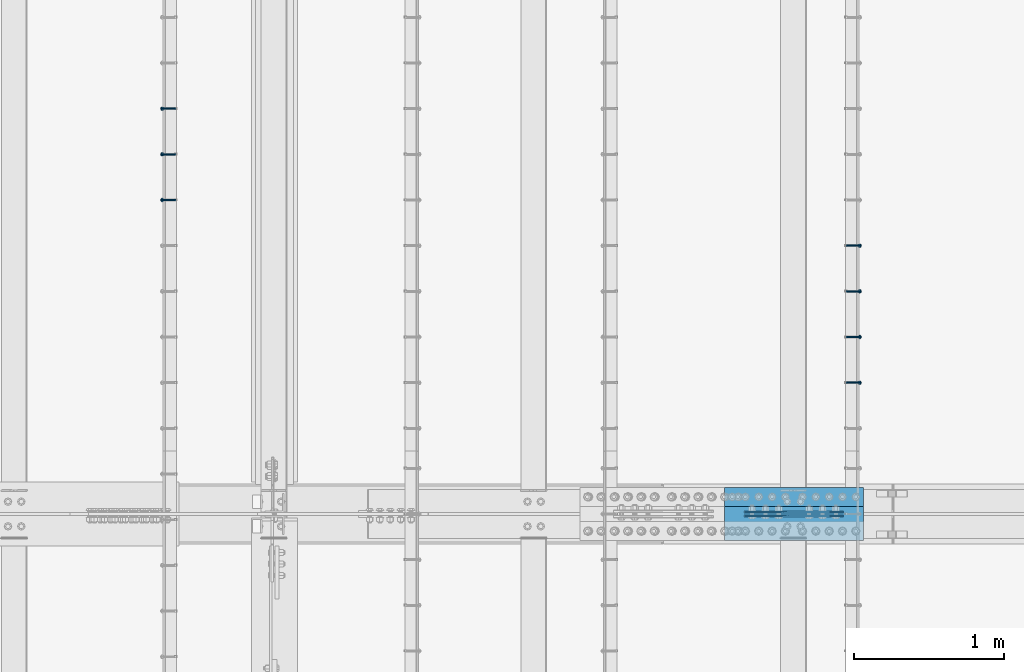
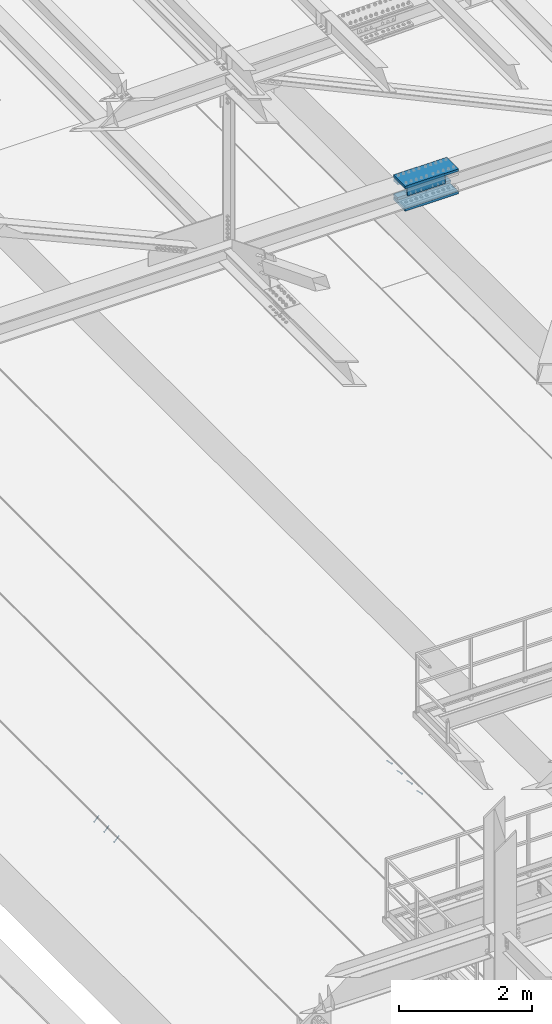
# One storey, part 2233 of 3843: 7 members, 6 beams, 3 elements without a shape of their own.
"""IFC2X3 building model written with IfcOpenShell, lengths in millimetres."""

from ifc_helpers import new_model, si_unit, frame, origin_with_axes, place, context, subcontext, project, spatial, faceted_brep, material, type_object, element, aggregate, save


model = new_model("IFC2X3")

# Units and contexts
model_context = context("Model", 3, precision=1e-05, world=origin_with_axes())
body_context = subcontext(model_context, "Body", "Model", "MODEL_VIEW")
ifc_project = project(units=[si_unit("LENGTHUNIT", "METRE", prefix="MILLI"), si_unit("AREAUNIT", "SQUARE_METRE"), si_unit("VOLUMEUNIT", "CUBIC_METRE"), si_unit("MASSUNIT", "GRAM", prefix="KILO"), si_unit("TIMEUNIT", "SECOND"), si_unit("PLANEANGLEUNIT", "RADIAN"), si_unit("SOLIDANGLEUNIT", "STERADIAN"), si_unit("THERMODYNAMICTEMPERATUREUNIT", "DEGREE_CELSIUS"), si_unit("LUMINOUSINTENSITYUNIT", "LUMEN")], contexts=[model_context])

# Site, building, storey
site_placement = place(None, origin_with_axes())
site = spatial("IfcSite", under=ifc_project, at=site_placement, CompositionType="ELEMENT")
building_placement = place(site_placement, origin_with_axes())
building = spatial("IfcBuilding", under=site, at=building_placement, Name="Undefined", CompositionType="ELEMENT")
storey_placement = place(building_placement, origin_with_axes())
storey = spatial("IfcBuildingStorey", under=building, at=storey_placement, Name="Undefined", CompositionType="ELEMENT", Elevation=0.0)

# Assembly, members
assembly_1_placement = place(storey_placement, origin_with_axes())
assembly_1 = element("IfcElementAssembly", 1, at=assembly_1_placement, inside=storey, Name="EMBED_ANGLE", AssemblyPlace="NOTDEFINED", PredefinedType="RIGID_FRAME")
ifc_material_1 = material(Name="STEEL/A108")
member_type = type_object("IfcMemberType", PredefinedType="NOTDEFINED")
member_1_placement = place(assembly_1_placement, frame((52815.2360419921, 34721.7996154785, 30446.6625), z_axis=(0.0, 1.0, 0.0), x_axis=(0.707106781186548, 0.0, -0.707106781186548)))
member_1 = element("IfcMember", 2, at=member_1_placement, type_object=member_type, material=ifc_material_1, Name="HEADED STUD ANCHOR", context=body_context, shape_type="Brep", body=[
    faceted_brep([(7.27595761418343e-12, -3.18000006675175, 5.5), (0.0, -5.49999999998363, 3.1800000667572), (118.110000000976, -5.49999999999091, 3.1800000667572), (118.110000000983, -3.18000006675175, 5.5), (0.0, -6.3499999046162, 0.0), (118.110000000968, -6.34999990461256, 0.0), (0.0, -5.49999999998363, -3.1800000667572), (118.110000000976, -5.49999999999091, -3.1800000667572), (7.27595761418343e-12, -3.18000006675175, -5.5), (118.110000000983, -3.18000006675175, -5.5), (7.27595761418343e-12, -1.81898940354586e-12, -6.34999990463257), (118.110000000968, -1.81898940354586e-12, -6.34999990463257), (0.0, 3.18000006675175, -5.5), (118.110000000968, 3.18000006674811, -5.5), (7.27595761418343e-12, 5.49999999998363, -3.1800000667572), (118.110000000983, 5.49999999998363, -3.1800000667572), (7.27595761418343e-12, 6.3499999046162, 0.0), (118.110000000976, 6.34999990461256, 0.0), (7.27595761418343e-12, 5.49999999998363, 3.1800000667572), (118.110000000983, 5.49999999998363, 3.1800000667572), (0.0, 3.18000006675175, 5.5), (118.110000000968, 3.18000006674811, 5.5), (7.27595761418343e-12, -1.81898940354586e-12, 6.34999990463257), (118.110000000968, -1.81898940354586e-12, 6.34999990463257), (120.650000000991, -10.9899997710909, 6.34999990463257), (120.650000000998, -6.34000015257152, 10.9899997711182), (120.650000000991, -12.6999998092379, 0.0), (120.650000000991, -10.9899997710909, -6.34999990463257), (120.650000000998, -6.34000015257152, -10.9899997711182), (120.650000000991, -1.81898940354586e-12, -12.6899995803833), (120.650000000991, 6.34000015257152, -10.9899997711182), (120.650000000998, 10.9899997710909, -6.34999990463257), (120.650000000991, 12.6999998092342, 0.0), (120.650000000998, 10.9899997710909, 6.34999990463257), (120.650000000991, 6.34000015257152, 10.9899997711182), (120.650000000991, -1.81898940354586e-12, 12.6899995803833), (127.000000001048, -10.9899997710945, 6.34999990463257), (127.000000001048, -6.34000015257152, 10.9899997711182), (127.000000001048, -12.6999998092342, 0.0), (127.000000001048, -10.9899997710945, -6.34999990463257), (127.000000001048, -6.34000015257152, -10.9899997711182), (127.000000001048, 1.81898940354586e-12, -12.6899995803833), (127.000000001048, 6.34000015256788, -10.9899997711182), (127.000000001048, 10.9899997710909, -6.34999990463257), (127.000000001048, 12.6999998092379, 0.0), (127.000000001048, 10.9899997710909, 6.34999990463257), (127.000000001048, 6.34000015256788, 10.9899997711182), (127.000000001048, 1.81898940354586e-12, 12.6899995803833)], [[[0, 1, 2, 3]], [[1, 4, 5, 2]], [[4, 6, 7, 5]], [[6, 8, 9, 7]], [[8, 10, 11, 9]], [[10, 12, 13, 11]], [[12, 14, 15, 13]], [[14, 16, 17, 15]], [[16, 18, 19, 17]], [[18, 20, 21, 19]], [[20, 22, 23, 21]], [[22, 0, 3, 23]], [[22, 20, 18, 16, 14, 12, 10, 8, 6, 4, 1, 0]], [[3, 2, 24, 25]], [[2, 5, 26, 24]], [[5, 7, 27, 26]], [[7, 9, 28, 27]], [[9, 11, 29, 28]], [[11, 13, 30, 29]], [[13, 15, 31, 30]], [[15, 17, 32, 31]], [[17, 19, 33, 32]], [[19, 21, 34, 33]], [[21, 23, 35, 34]], [[23, 3, 25, 35]], [[25, 24, 36, 37]], [[24, 26, 38, 36]], [[26, 27, 39, 38]], [[27, 28, 40, 39]], [[28, 29, 41, 40]], [[29, 30, 42, 41]], [[30, 31, 43, 42]], [[31, 32, 44, 43]], [[32, 33, 45, 44]], [[33, 34, 46, 45]], [[34, 35, 47, 46]], [[35, 25, 37, 47]], [[38, 39, 40, 41, 42, 43, 44, 45, 46, 47, 37, 36]]]),
])
member_2_placement = place(assembly_1_placement, frame((52815.2360419921, 35026.5996154785, 30446.6625), z_axis=(0.0, 1.0, 0.0), x_axis=(0.707106781186548, 0.0, -0.707106781186548)))
member_2 = element("IfcMember", 3, at=member_2_placement, type_object=member_type, material=ifc_material_1, Name="HEADED STUD ANCHOR", context=body_context, shape_type="Brep", body=[
    faceted_brep([(7.27595761418343e-12, -3.18000006675175, 5.5), (0.0, -5.49999999998363, 3.1800000667572), (118.110000000976, -5.49999999999091, 3.1800000667572), (118.110000000983, -3.18000006675175, 5.5), (0.0, -6.3499999046162, 0.0), (118.110000000968, -6.34999990461256, 0.0), (0.0, -5.49999999998363, -3.1800000667572), (118.110000000976, -5.49999999999091, -3.1800000667572), (7.27595761418343e-12, -3.18000006675175, -5.5), (118.110000000983, -3.18000006675175, -5.5), (7.27595761418343e-12, -1.81898940354586e-12, -6.34999990463257), (118.110000000968, -1.81898940354586e-12, -6.34999990463257), (0.0, 3.18000006675175, -5.5), (118.110000000968, 3.18000006674811, -5.5), (7.27595761418343e-12, 5.49999999998363, -3.1800000667572), (118.110000000983, 5.49999999998363, -3.1800000667572), (7.27595761418343e-12, 6.3499999046162, 0.0), (118.110000000976, 6.34999990461256, 0.0), (7.27595761418343e-12, 5.49999999998363, 3.1800000667572), (118.110000000983, 5.49999999998363, 3.1800000667572), (0.0, 3.18000006675175, 5.5), (118.110000000968, 3.18000006674811, 5.5), (7.27595761418343e-12, -1.81898940354586e-12, 6.34999990463257), (118.110000000968, -1.81898940354586e-12, 6.34999990463257), (120.650000000991, -10.9899997710909, 6.34999990463257), (120.650000000998, -6.34000015257152, 10.9899997711182), (120.650000000991, -12.6999998092379, 0.0), (120.650000000991, -10.9899997710909, -6.34999990463257), (120.650000000998, -6.34000015257152, -10.9899997711182), (120.650000000991, -1.81898940354586e-12, -12.6899995803833), (120.650000000991, 6.34000015257152, -10.9899997711182), (120.650000000998, 10.9899997710909, -6.34999990463257), (120.650000000991, 12.6999998092342, 0.0), (120.650000000998, 10.9899997710909, 6.34999990463257), (120.650000000991, 6.34000015257152, 10.9899997711182), (120.650000000991, -1.81898940354586e-12, 12.6899995803833), (127.000000001048, -10.9899997710945, 6.34999990463257), (127.000000001048, -6.34000015257152, 10.9899997711182), (127.000000001048, -12.6999998092342, 0.0), (127.000000001048, -10.9899997710945, -6.34999990463257), (127.000000001048, -6.34000015257152, -10.9899997711182), (127.000000001048, 1.81898940354586e-12, -12.6899995803833), (127.000000001048, 6.34000015256788, -10.9899997711182), (127.000000001048, 10.9899997710909, -6.34999990463257), (127.000000001048, 12.6999998092379, 0.0), (127.000000001048, 10.9899997710909, 6.34999990463257), (127.000000001048, 6.34000015256788, 10.9899997711182), (127.000000001048, 1.81898940354586e-12, 12.6899995803833)], [[[0, 1, 2, 3]], [[1, 4, 5, 2]], [[4, 6, 7, 5]], [[6, 8, 9, 7]], [[8, 10, 11, 9]], [[10, 12, 13, 11]], [[12, 14, 15, 13]], [[14, 16, 17, 15]], [[16, 18, 19, 17]], [[18, 20, 21, 19]], [[20, 22, 23, 21]], [[22, 0, 3, 23]], [[22, 20, 18, 16, 14, 12, 10, 8, 6, 4, 1, 0]], [[3, 2, 24, 25]], [[2, 5, 26, 24]], [[5, 7, 27, 26]], [[7, 9, 28, 27]], [[9, 11, 29, 28]], [[11, 13, 30, 29]], [[13, 15, 31, 30]], [[15, 17, 32, 31]], [[17, 19, 33, 32]], [[19, 21, 34, 33]], [[21, 23, 35, 34]], [[23, 3, 25, 35]], [[25, 24, 36, 37]], [[24, 26, 38, 36]], [[26, 27, 39, 38]], [[27, 28, 40, 39]], [[28, 29, 41, 40]], [[29, 30, 42, 41]], [[30, 31, 43, 42]], [[31, 32, 44, 43]], [[32, 33, 45, 44]], [[33, 34, 46, 45]], [[34, 35, 47, 46]], [[35, 25, 37, 47]], [[38, 39, 40, 41, 42, 43, 44, 45, 46, 47, 37, 36]]]),
])
member_3_placement = place(assembly_1_placement, frame((52815.2360419921, 35331.3996154785, 30446.6625), z_axis=(0.0, 1.0, 0.0), x_axis=(0.707106781186548, 0.0, -0.707106781186548)))
member_3 = element("IfcMember", 4, at=member_3_placement, type_object=member_type, material=ifc_material_1, Name="HEADED STUD ANCHOR", context=body_context, shape_type="Brep", body=[
    faceted_brep([(7.27595761418343e-12, -3.18000006675175, 5.5), (0.0, -5.49999999998363, 3.1800000667572), (118.110000000976, -5.49999999999091, 3.1800000667572), (118.110000000983, -3.18000006675175, 5.5), (0.0, -6.3499999046162, 0.0), (118.110000000968, -6.34999990461256, 0.0), (0.0, -5.49999999998363, -3.1800000667572), (118.110000000976, -5.49999999999091, -3.1800000667572), (7.27595761418343e-12, -3.18000006675175, -5.5), (118.110000000983, -3.18000006675175, -5.5), (7.27595761418343e-12, -1.81898940354586e-12, -6.34999990463257), (118.110000000968, -1.81898940354586e-12, -6.34999990463257), (0.0, 3.18000006675175, -5.5), (118.110000000968, 3.18000006674811, -5.5), (7.27595761418343e-12, 5.49999999998363, -3.1800000667572), (118.110000000983, 5.49999999998363, -3.1800000667572), (7.27595761418343e-12, 6.3499999046162, 0.0), (118.110000000976, 6.34999990461256, 0.0), (7.27595761418343e-12, 5.49999999998363, 3.1800000667572), (118.110000000983, 5.49999999998363, 3.1800000667572), (0.0, 3.18000006675175, 5.5), (118.110000000968, 3.18000006674811, 5.5), (7.27595761418343e-12, -1.81898940354586e-12, 6.34999990463257), (118.110000000968, -1.81898940354586e-12, 6.34999990463257), (120.650000000991, -10.9899997710909, 6.34999990463257), (120.650000000998, -6.34000015257152, 10.9899997711182), (120.650000000991, -12.6999998092379, 0.0), (120.650000000991, -10.9899997710909, -6.34999990463257), (120.650000000998, -6.34000015257152, -10.9899997711182), (120.650000000991, -1.81898940354586e-12, -12.6899995803833), (120.650000000991, 6.34000015257152, -10.9899997711182), (120.650000000998, 10.9899997710909, -6.34999990463257), (120.650000000991, 12.6999998092342, 0.0), (120.650000000998, 10.9899997710909, 6.34999990463257), (120.650000000991, 6.34000015257152, 10.9899997711182), (120.650000000991, -1.81898940354586e-12, 12.6899995803833), (127.000000001048, -10.9899997710945, 6.34999990463257), (127.000000001048, -6.34000015257152, 10.9899997711182), (127.000000001048, -12.6999998092342, 0.0), (127.000000001048, -10.9899997710945, -6.34999990463257), (127.000000001048, -6.34000015257152, -10.9899997711182), (127.000000001048, 1.81898940354586e-12, -12.6899995803833), (127.000000001048, 6.34000015256788, -10.9899997711182), (127.000000001048, 10.9899997710909, -6.34999990463257), (127.000000001048, 12.6999998092379, 0.0), (127.000000001048, 10.9899997710909, 6.34999990463257), (127.000000001048, 6.34000015256788, 10.9899997711182), (127.000000001048, 1.81898940354586e-12, 12.6899995803833)], [[[0, 1, 2, 3]], [[1, 4, 5, 2]], [[4, 6, 7, 5]], [[6, 8, 9, 7]], [[8, 10, 11, 9]], [[10, 12, 13, 11]], [[12, 14, 15, 13]], [[14, 16, 17, 15]], [[16, 18, 19, 17]], [[18, 20, 21, 19]], [[20, 22, 23, 21]], [[22, 0, 3, 23]], [[22, 20, 18, 16, 14, 12, 10, 8, 6, 4, 1, 0]], [[3, 2, 24, 25]], [[2, 5, 26, 24]], [[5, 7, 27, 26]], [[7, 9, 28, 27]], [[9, 11, 29, 28]], [[11, 13, 30, 29]], [[13, 15, 31, 30]], [[15, 17, 32, 31]], [[17, 19, 33, 32]], [[19, 21, 34, 33]], [[21, 23, 35, 34]], [[23, 3, 25, 35]], [[25, 24, 36, 37]], [[24, 26, 38, 36]], [[26, 27, 39, 38]], [[27, 28, 40, 39]], [[28, 29, 41, 40]], [[29, 30, 42, 41]], [[30, 31, 43, 42]], [[31, 32, 44, 43]], [[32, 33, 45, 44]], [[33, 34, 46, 45]], [[34, 35, 47, 46]], [[35, 25, 37, 47]], [[38, 39, 40, 41, 42, 43, 44, 45, 46, 47, 37, 36]]]),
])
member_4_placement = place(assembly_1_placement, frame((52815.2360419921, 35636.1996154785, 30446.6625), z_axis=(0.0, 1.0, 0.0), x_axis=(0.707106781186548, 0.0, -0.707106781186548)))
member_4 = element("IfcMember", 5, at=member_4_placement, type_object=member_type, material=ifc_material_1, Name="HEADED STUD ANCHOR", context=body_context, shape_type="Brep", body=[
    faceted_brep([(7.27595761418343e-12, -3.18000006675175, 5.5), (0.0, -5.49999999998363, 3.1800000667572), (118.110000000976, -5.49999999999091, 3.1800000667572), (118.110000000983, -3.18000006675175, 5.5), (0.0, -6.3499999046162, 0.0), (118.110000000968, -6.34999990461256, 0.0), (0.0, -5.49999999998363, -3.1800000667572), (118.110000000976, -5.49999999999091, -3.1800000667572), (7.27595761418343e-12, -3.18000006675175, -5.5), (118.110000000983, -3.18000006675175, -5.5), (7.27595761418343e-12, -1.81898940354586e-12, -6.34999990463257), (118.110000000968, -1.81898940354586e-12, -6.34999990463257), (0.0, 3.18000006675175, -5.5), (118.110000000968, 3.18000006674811, -5.5), (7.27595761418343e-12, 5.49999999998363, -3.1800000667572), (118.110000000983, 5.49999999998363, -3.1800000667572), (7.27595761418343e-12, 6.3499999046162, 0.0), (118.110000000976, 6.34999990461256, 0.0), (7.27595761418343e-12, 5.49999999998363, 3.1800000667572), (118.110000000983, 5.49999999998363, 3.1800000667572), (0.0, 3.18000006675175, 5.5), (118.110000000968, 3.18000006674811, 5.5), (7.27595761418343e-12, -1.81898940354586e-12, 6.34999990463257), (118.110000000968, -1.81898940354586e-12, 6.34999990463257), (120.650000000991, -10.9899997710909, 6.34999990463257), (120.650000000998, -6.34000015257152, 10.9899997711182), (120.650000000991, -12.6999998092379, 0.0), (120.650000000991, -10.9899997710909, -6.34999990463257), (120.650000000998, -6.34000015257152, -10.9899997711182), (120.650000000991, -1.81898940354586e-12, -12.6899995803833), (120.650000000991, 6.34000015257152, -10.9899997711182), (120.650000000998, 10.9899997710909, -6.34999990463257), (120.650000000991, 12.6999998092342, 0.0), (120.650000000998, 10.9899997710909, 6.34999990463257), (120.650000000991, 6.34000015257152, 10.9899997711182), (120.650000000991, -1.81898940354586e-12, 12.6899995803833), (127.000000001048, -10.9899997710945, 6.34999990463257), (127.000000001048, -6.34000015257152, 10.9899997711182), (127.000000001048, -12.6999998092342, 0.0), (127.000000001048, -10.9899997710945, -6.34999990463257), (127.000000001048, -6.34000015257152, -10.9899997711182), (127.000000001048, 1.81898940354586e-12, -12.6899995803833), (127.000000001048, 6.34000015256788, -10.9899997711182), (127.000000001048, 10.9899997710909, -6.34999990463257), (127.000000001048, 12.6999998092379, 0.0), (127.000000001048, 10.9899997710909, 6.34999990463257), (127.000000001048, 6.34000015256788, 10.9899997711182), (127.000000001048, 1.81898940354586e-12, 12.6899995803833)], [[[0, 1, 2, 3]], [[1, 4, 5, 2]], [[4, 6, 7, 5]], [[6, 8, 9, 7]], [[8, 10, 11, 9]], [[10, 12, 13, 11]], [[12, 14, 15, 13]], [[14, 16, 17, 15]], [[16, 18, 19, 17]], [[18, 20, 21, 19]], [[20, 22, 23, 21]], [[22, 0, 3, 23]], [[22, 20, 18, 16, 14, 12, 10, 8, 6, 4, 1, 0]], [[3, 2, 24, 25]], [[2, 5, 26, 24]], [[5, 7, 27, 26]], [[7, 9, 28, 27]], [[9, 11, 29, 28]], [[11, 13, 30, 29]], [[13, 15, 31, 30]], [[15, 17, 32, 31]], [[17, 19, 33, 32]], [[19, 21, 34, 33]], [[21, 23, 35, 34]], [[23, 3, 25, 35]], [[25, 24, 36, 37]], [[24, 26, 38, 36]], [[26, 27, 39, 38]], [[27, 28, 40, 39]], [[28, 29, 41, 40]], [[29, 30, 42, 41]], [[30, 31, 43, 42]], [[31, 32, 44, 43]], [[32, 33, 45, 44]], [[33, 34, 46, 45]], [[34, 35, 47, 46]], [[35, 25, 37, 47]], [[38, 39, 40, 41, 42, 43, 44, 45, 46, 47, 37, 36]]]),
])
aggregate(assembly_1, [member_1, member_2, member_3, member_4])

assembly_2_placement = place(storey_placement, origin_with_axes())
assembly_2 = element("IfcElementAssembly", 6, at=assembly_2_placement, inside=storey, Name="EMBED_ANGLE", AssemblyPlace="NOTDEFINED", PredefinedType="RIGID_FRAME")
member_5_placement = place(assembly_2_placement, frame((48335.3741210938, 35941.0003845215, 30446.6625), z_axis=(0.0, -1.0, 0.0), x_axis=(-0.707106781186548, 0.0, -0.707106781186548)))
member_5 = element("IfcMember", 7, at=member_5_placement, type_object=member_type, material=ifc_material_1, Name="HEADED STUD ANCHOR", context=body_context, shape_type="Brep", body=[
    faceted_brep([(7.27595761418343e-12, -3.18000006675175, 5.5), (0.0, -5.49999999998363, 3.1800000667572), (118.110000000976, -5.49999999999091, 3.1800000667572), (118.110000000983, -3.18000006675175, 5.5), (0.0, -6.3499999046162, 0.0), (118.110000000968, -6.34999990461256, 0.0), (0.0, -5.49999999998363, -3.1800000667572), (118.110000000976, -5.49999999999091, -3.1800000667572), (7.27595761418343e-12, -3.18000006675175, -5.5), (118.110000000983, -3.18000006675175, -5.5), (7.27595761418343e-12, -1.81898940354586e-12, -6.34999990463257), (118.110000000968, -1.81898940354586e-12, -6.34999990463257), (0.0, 3.18000006675175, -5.5), (118.110000000968, 3.18000006674811, -5.5), (7.27595761418343e-12, 5.49999999998363, -3.1800000667572), (118.110000000983, 5.49999999998363, -3.1800000667572), (7.27595761418343e-12, 6.3499999046162, 0.0), (118.110000000976, 6.34999990461256, 0.0), (7.27595761418343e-12, 5.49999999998363, 3.1800000667572), (118.110000000983, 5.49999999998363, 3.1800000667572), (0.0, 3.18000006675175, 5.5), (118.110000000968, 3.18000006674811, 5.5), (7.27595761418343e-12, -1.81898940354586e-12, 6.34999990463257), (118.110000000968, -1.81898940354586e-12, 6.34999990463257), (120.650000000991, -10.9899997710909, 6.34999990463257), (120.650000000998, -6.34000015257152, 10.9899997711182), (120.650000000991, -12.6999998092379, 0.0), (120.650000000991, -10.9899997710909, -6.34999990463257), (120.650000000998, -6.34000015257152, -10.9899997711182), (120.650000000991, -1.81898940354586e-12, -12.6899995803833), (120.650000000991, 6.34000015257152, -10.9899997711182), (120.650000000998, 10.9899997710909, -6.34999990463257), (120.650000000991, 12.6999998092342, 0.0), (120.650000000998, 10.9899997710909, 6.34999990463257), (120.650000000991, 6.34000015257152, 10.9899997711182), (120.650000000991, -1.81898940354586e-12, 12.6899995803833), (127.000000001048, -10.9899997710945, 6.34999990463257), (127.000000001048, -6.34000015257152, 10.9899997711182), (127.000000001048, -12.6999998092342, 0.0), (127.000000001048, -10.9899997710945, -6.34999990463257), (127.000000001048, -6.34000015257152, -10.9899997711182), (127.000000001048, 1.81898940354586e-12, -12.6899995803833), (127.000000001048, 6.34000015256788, -10.9899997711182), (127.000000001048, 10.9899997710909, -6.34999990463257), (127.000000001048, 12.6999998092379, 0.0), (127.000000001048, 10.9899997710909, 6.34999990463257), (127.000000001048, 6.34000015256788, 10.9899997711182), (127.000000001048, 1.81898940354586e-12, 12.6899995803833)], [[[0, 1, 2, 3]], [[1, 4, 5, 2]], [[4, 6, 7, 5]], [[6, 8, 9, 7]], [[8, 10, 11, 9]], [[10, 12, 13, 11]], [[12, 14, 15, 13]], [[14, 16, 17, 15]], [[16, 18, 19, 17]], [[18, 20, 21, 19]], [[20, 22, 23, 21]], [[22, 0, 3, 23]], [[22, 20, 18, 16, 14, 12, 10, 8, 6, 4, 1, 0]], [[3, 2, 24, 25]], [[2, 5, 26, 24]], [[5, 7, 27, 26]], [[7, 9, 28, 27]], [[9, 11, 29, 28]], [[11, 13, 30, 29]], [[13, 15, 31, 30]], [[15, 17, 32, 31]], [[17, 19, 33, 32]], [[19, 21, 34, 33]], [[21, 23, 35, 34]], [[23, 3, 25, 35]], [[25, 24, 36, 37]], [[24, 26, 38, 36]], [[26, 27, 39, 38]], [[27, 28, 40, 39]], [[28, 29, 41, 40]], [[29, 30, 42, 41]], [[30, 31, 43, 42]], [[31, 32, 44, 43]], [[32, 33, 45, 44]], [[33, 34, 46, 45]], [[34, 35, 47, 46]], [[35, 25, 37, 47]], [[38, 39, 40, 41, 42, 43, 44, 45, 46, 47, 37, 36]]]),
])
member_6_placement = place(assembly_2_placement, frame((48335.3741210938, 36245.8003845215, 30446.6625), z_axis=(0.0, -1.0, 0.0), x_axis=(-0.707106781186548, 0.0, -0.707106781186548)))
member_6 = element("IfcMember", 8, at=member_6_placement, type_object=member_type, material=ifc_material_1, Name="HEADED STUD ANCHOR", context=body_context, shape_type="Brep", body=[
    faceted_brep([(7.27595761418343e-12, -3.18000006675175, 5.5), (0.0, -5.49999999998363, 3.1800000667572), (118.110000000976, -5.49999999999091, 3.1800000667572), (118.110000000983, -3.18000006675175, 5.5), (0.0, -6.3499999046162, 0.0), (118.110000000968, -6.34999990461256, 0.0), (0.0, -5.49999999998363, -3.1800000667572), (118.110000000976, -5.49999999999091, -3.1800000667572), (7.27595761418343e-12, -3.18000006675175, -5.5), (118.110000000983, -3.18000006675175, -5.5), (7.27595761418343e-12, -1.81898940354586e-12, -6.34999990463257), (118.110000000968, -1.81898940354586e-12, -6.34999990463257), (0.0, 3.18000006675175, -5.5), (118.110000000968, 3.18000006674811, -5.5), (7.27595761418343e-12, 5.49999999998363, -3.1800000667572), (118.110000000983, 5.49999999998363, -3.1800000667572), (7.27595761418343e-12, 6.3499999046162, 0.0), (118.110000000976, 6.34999990461256, 0.0), (7.27595761418343e-12, 5.49999999998363, 3.1800000667572), (118.110000000983, 5.49999999998363, 3.1800000667572), (0.0, 3.18000006675175, 5.5), (118.110000000968, 3.18000006674811, 5.5), (7.27595761418343e-12, -1.81898940354586e-12, 6.34999990463257), (118.110000000968, -1.81898940354586e-12, 6.34999990463257), (120.650000000991, -10.9899997710909, 6.34999990463257), (120.650000000998, -6.34000015257152, 10.9899997711182), (120.650000000991, -12.6999998092379, 0.0), (120.650000000991, -10.9899997710909, -6.34999990463257), (120.650000000998, -6.34000015257152, -10.9899997711182), (120.650000000991, -1.81898940354586e-12, -12.6899995803833), (120.650000000991, 6.34000015257152, -10.9899997711182), (120.650000000998, 10.9899997710909, -6.34999990463257), (120.650000000991, 12.6999998092342, 0.0), (120.650000000998, 10.9899997710909, 6.34999990463257), (120.650000000991, 6.34000015257152, 10.9899997711182), (120.650000000991, -1.81898940354586e-12, 12.6899995803833), (127.000000001048, -10.9899997710945, 6.34999990463257), (127.000000001048, -6.34000015257152, 10.9899997711182), (127.000000001048, -12.6999998092342, 0.0), (127.000000001048, -10.9899997710945, -6.34999990463257), (127.000000001048, -6.34000015257152, -10.9899997711182), (127.000000001048, 1.81898940354586e-12, -12.6899995803833), (127.000000001048, 6.34000015256788, -10.9899997711182), (127.000000001048, 10.9899997710909, -6.34999990463257), (127.000000001048, 12.6999998092379, 0.0), (127.000000001048, 10.9899997710909, 6.34999990463257), (127.000000001048, 6.34000015256788, 10.9899997711182), (127.000000001048, 1.81898940354586e-12, 12.6899995803833)], [[[0, 1, 2, 3]], [[1, 4, 5, 2]], [[4, 6, 7, 5]], [[6, 8, 9, 7]], [[8, 10, 11, 9]], [[10, 12, 13, 11]], [[12, 14, 15, 13]], [[14, 16, 17, 15]], [[16, 18, 19, 17]], [[18, 20, 21, 19]], [[20, 22, 23, 21]], [[22, 0, 3, 23]], [[22, 20, 18, 16, 14, 12, 10, 8, 6, 4, 1, 0]], [[3, 2, 24, 25]], [[2, 5, 26, 24]], [[5, 7, 27, 26]], [[7, 9, 28, 27]], [[9, 11, 29, 28]], [[11, 13, 30, 29]], [[13, 15, 31, 30]], [[15, 17, 32, 31]], [[17, 19, 33, 32]], [[19, 21, 34, 33]], [[21, 23, 35, 34]], [[23, 3, 25, 35]], [[25, 24, 36, 37]], [[24, 26, 38, 36]], [[26, 27, 39, 38]], [[27, 28, 40, 39]], [[28, 29, 41, 40]], [[29, 30, 42, 41]], [[30, 31, 43, 42]], [[31, 32, 44, 43]], [[32, 33, 45, 44]], [[33, 34, 46, 45]], [[34, 35, 47, 46]], [[35, 25, 37, 47]], [[38, 39, 40, 41, 42, 43, 44, 45, 46, 47, 37, 36]]]),
])
member_7_placement = place(assembly_2_placement, frame((48335.3741210938, 36550.6003845215, 30446.6625), z_axis=(0.0, -1.0, 0.0), x_axis=(-0.707106781186548, 0.0, -0.707106781186548)))
member_7 = element("IfcMember", 9, at=member_7_placement, type_object=member_type, material=ifc_material_1, Name="HEADED STUD ANCHOR", context=body_context, shape_type="Brep", body=[
    faceted_brep([(7.27595761418343e-12, -3.18000006675175, 5.5), (0.0, -5.49999999998363, 3.1800000667572), (118.110000000976, -5.49999999999091, 3.1800000667572), (118.110000000983, -3.18000006675175, 5.5), (0.0, -6.3499999046162, 0.0), (118.110000000968, -6.34999990461256, 0.0), (0.0, -5.49999999998363, -3.1800000667572), (118.110000000976, -5.49999999999091, -3.1800000667572), (7.27595761418343e-12, -3.18000006675175, -5.5), (118.110000000983, -3.18000006675175, -5.5), (7.27595761418343e-12, -1.81898940354586e-12, -6.34999990463257), (118.110000000968, -1.81898940354586e-12, -6.34999990463257), (0.0, 3.18000006675175, -5.5), (118.110000000968, 3.18000006674811, -5.5), (7.27595761418343e-12, 5.49999999998363, -3.1800000667572), (118.110000000983, 5.49999999998363, -3.1800000667572), (7.27595761418343e-12, 6.3499999046162, 0.0), (118.110000000976, 6.34999990461256, 0.0), (7.27595761418343e-12, 5.49999999998363, 3.1800000667572), (118.110000000983, 5.49999999998363, 3.1800000667572), (0.0, 3.18000006675175, 5.5), (118.110000000968, 3.18000006674811, 5.5), (7.27595761418343e-12, -1.81898940354586e-12, 6.34999990463257), (118.110000000968, -1.81898940354586e-12, 6.34999990463257), (120.650000000991, -10.9899997710909, 6.34999990463257), (120.650000000998, -6.34000015257152, 10.9899997711182), (120.650000000991, -12.6999998092379, 0.0), (120.650000000991, -10.9899997710909, -6.34999990463257), (120.650000000998, -6.34000015257152, -10.9899997711182), (120.650000000991, -1.81898940354586e-12, -12.6899995803833), (120.650000000991, 6.34000015257152, -10.9899997711182), (120.650000000998, 10.9899997710909, -6.34999990463257), (120.650000000991, 12.6999998092342, 0.0), (120.650000000998, 10.9899997710909, 6.34999990463257), (120.650000000991, 6.34000015257152, 10.9899997711182), (120.650000000991, -1.81898940354586e-12, 12.6899995803833), (127.000000001048, -10.9899997710945, 6.34999990463257), (127.000000001048, -6.34000015257152, 10.9899997711182), (127.000000001048, -12.6999998092342, 0.0), (127.000000001048, -10.9899997710945, -6.34999990463257), (127.000000001048, -6.34000015257152, -10.9899997711182), (127.000000001048, 1.81898940354586e-12, -12.6899995803833), (127.000000001048, 6.34000015256788, -10.9899997711182), (127.000000001048, 10.9899997710909, -6.34999990463257), (127.000000001048, 12.6999998092379, 0.0), (127.000000001048, 10.9899997710909, 6.34999990463257), (127.000000001048, 6.34000015256788, 10.9899997711182), (127.000000001048, 1.81898940354586e-12, 12.6899995803833)], [[[0, 1, 2, 3]], [[1, 4, 5, 2]], [[4, 6, 7, 5]], [[6, 8, 9, 7]], [[8, 10, 11, 9]], [[10, 12, 13, 11]], [[12, 14, 15, 13]], [[14, 16, 17, 15]], [[16, 18, 19, 17]], [[18, 20, 21, 19]], [[20, 22, 23, 21]], [[22, 0, 3, 23]], [[22, 20, 18, 16, 14, 12, 10, 8, 6, 4, 1, 0]], [[3, 2, 24, 25]], [[2, 5, 26, 24]], [[5, 7, 27, 26]], [[7, 9, 28, 27]], [[9, 11, 29, 28]], [[11, 13, 30, 29]], [[13, 15, 31, 30]], [[15, 17, 32, 31]], [[17, 19, 33, 32]], [[19, 21, 34, 33]], [[21, 23, 35, 34]], [[23, 3, 25, 35]], [[25, 24, 36, 37]], [[24, 26, 38, 36]], [[26, 27, 39, 38]], [[27, 28, 40, 39]], [[28, 29, 41, 40]], [[29, 30, 42, 41]], [[30, 31, 43, 42]], [[31, 32, 44, 43]], [[32, 33, 45, 44]], [[33, 34, 46, 45]], [[34, 35, 47, 46]], [[35, 25, 37, 47]], [[38, 39, 40, 41, 42, 43, 44, 45, 46, 47, 37, 36]]]),
])
aggregate(assembly_2, [member_5, member_6, member_7])

# Assembly, beams
assembly_3_placement = place(storey_placement, origin_with_axes())
assembly_3 = element("IfcElementAssembly", 10, at=assembly_3_placement, inside=storey, Name="BEAM", AssemblyPlace="NOTDEFINED", PredefinedType="RIGID_FRAME")
ifc_material_2 = material(Name="STEEL/A572-50")
beam_type_1 = type_object("IfcBeamType", PredefinedType="NOTDEFINED")
beam_1_placement = place(assembly_3_placement, frame((52133.5000385969, 33832.00625, 42254.0613952203), z_axis=(-0.00048281500021403, 0.0, 0.999999883444831), x_axis=(0.999999883444831, 0.0, 0.000482815000217081)))
beam_1 = element("IfcBeam", 11, at=beam_1_placement, type_object=beam_type_1, material=ifc_material_2, Name="PLATE", context=body_context, shape_type="Brep", body=[
    faceted_brep([(1.45519152283669e-11, 6.35000000000582, -88.8999999998996), (0.0, 6.34999999999854, 88.9000015258789), (660.399999982677, 6.35000000000582, 88.8999999999651), (660.399999982707, 6.35000000000582, -88.8999999998268), (0.0, -6.34999999999854, 88.9000015258789), (660.399999982677, -6.35000000000582, 88.8999999999651), (1.45519152283669e-11, -6.35000000000582, -88.8999999998996), (660.399999982707, -6.35000000000582, -88.8999999998268)], [[[0, 1, 2, 3]], [[1, 4, 5, 2]], [[4, 6, 7, 5]], [[6, 0, 3, 7]], [[5, 7, 3, 2]], [[6, 4, 1, 0]]]),
])
beam_2_placement = place(assembly_3_placement, frame((52133.5000385969, 33858.99375, 42254.0613952203), z_axis=(-0.00048281500021403, 0.0, 0.999999883444831), x_axis=(0.999999883444831, 0.0, 0.000482815000217081)))
beam_2 = element("IfcBeam", 12, at=beam_2_placement, type_object=beam_type_1, material=ifc_material_2, Name="PLATE", context=body_context, shape_type="Brep", body=[
    faceted_brep([(1.45519152283669e-11, 6.35000000000582, -88.8999999998996), (0.0, 6.34999999999854, 88.9000015258789), (660.399999982677, 6.35000000000582, 88.8999999999651), (660.399999982707, 6.35000000000582, -88.8999999998268), (0.0, -6.34999999999854, 88.9000015258789), (660.399999982677, -6.35000000000582, 88.8999999999651), (1.45519152283669e-11, -6.35000000000582, -88.8999999998996), (660.399999982707, -6.35000000000582, -88.8999999998268)], [[[0, 1, 2, 3]], [[1, 4, 5, 2]], [[4, 6, 7, 5]], [[6, 0, 3, 7]], [[5, 7, 3, 2]], [[6, 4, 1, 0]]]),
])
beam_type_2 = type_object("IfcBeamType", PredefinedType="NOTDEFINED")
beam_3_placement = place(assembly_3_placement, frame((52000.0504131929, 33845.5, 42460.3719878295), z_axis=(0.0, -1.0, 0.0), x_axis=(0.999999883444831, 0.0, 0.000482815000217081)))
beam_3 = element("IfcBeam", 13, at=beam_3_placement, type_object=beam_type_2, material=ifc_material_2, Name="PLATE", context=body_context, shape_type="Brep", body=[
    faceted_brep([(0.0, 22.2249999999767, -177.800000000003), (0.0, 22.2249999999767, 177.800000000003), (927.099999958984, 22.2250000000859, 177.800000000003), (927.099999958984, 22.2250000000859, -177.800000000003), (0.0, -22.2249999999694, 177.800000000003), (927.099999958984, -22.2249999998749, 177.800000000003), (0.0, -22.2249999999694, -177.800000000003), (927.099999958984, -22.2249999998749, -177.800000000003)], [[[0, 1, 2, 3]], [[1, 4, 5, 2]], [[4, 6, 7, 5]], [[6, 0, 3, 7]], [[5, 7, 3, 2]], [[6, 4, 1, 0]]]),
])
beam_4_placement = place(assembly_3_placement, frame((52000.2496950832, 33845.5, 42047.6220358918), z_axis=(0.0, -1.0, 0.0), x_axis=(0.999999883444831, 0.0, 0.000482815000217081)))
beam_4 = element("IfcBeam", 14, at=beam_4_placement, type_object=beam_type_2, material=ifc_material_2, Name="PLATE", context=body_context, shape_type="Brep", body=[
    faceted_brep([(0.0, 22.2249999999767, -177.800000000003), (0.0, 22.2249999999767, 177.800000000003), (927.099999958984, 22.2250000000859, 177.800000000003), (927.099999958984, 22.2250000000859, -177.800000000003), (0.0, -22.2249999999694, 177.800000000003), (927.099999958984, -22.2249999998749, 177.800000000003), (0.0, -22.2249999999694, -177.800000000003), (927.099999958984, -22.2249999998749, -177.800000000003)], [[[0, 1, 2, 3]], [[1, 4, 5, 2]], [[4, 6, 7, 5]], [[6, 0, 3, 7]], [[5, 7, 3, 2]], [[6, 4, 1, 0]]]),
])
beam_type_3 = type_object("IfcBeamType", PredefinedType="NOTDEFINED")
beam_5_placement = place(assembly_3_placement, frame((52927.1832633038, 33959.8, 42392.5571135293), z_axis=(0.0, -1.0, 0.0), x_axis=(-0.999999883445314, 0.0, -0.000482814000210543)))
beam_5 = element("IfcBeam", 15, at=beam_5_placement, type_object=beam_type_3, material=ifc_material_2, Name="PLATE", context=body_context, shape_type="Brep", body=[
    faceted_brep([(-7.27595761418343e-11, 22.2250000000786, -63.5), (-7.27595761418343e-11, 22.2250000000786, 63.5), (927.099999951592, 22.2250000031054, 63.5), (927.099999951592, 22.2250000031054, -63.5), (6.54836185276508e-11, -22.2250000000713, 63.5), (927.099999951744, -22.2249999970372, 63.5), (6.54836185276508e-11, -22.2250000000713, -63.5), (927.099999951744, -22.2249999970372, -63.5)], [[[0, 1, 2, 3]], [[1, 4, 5, 2]], [[4, 6, 7, 5]], [[6, 0, 3, 7]], [[5, 7, 3, 2]], [[6, 4, 1, 0]]]),
])
beam_6_placement = place(assembly_3_placement, frame((52927.3166288765, 33959.8, 42116.3321457606), z_axis=(0.0, -1.0, 0.0), x_axis=(-0.999999883445314, 0.0, -0.000482814000210543)))
beam_6 = element("IfcBeam", 16, at=beam_6_placement, type_object=beam_type_3, material=ifc_material_2, Name="PLATE", context=body_context, shape_type="Brep", body=[
    faceted_brep([(-7.27595761418343e-11, 22.2250000000786, -63.5), (-7.27595761418343e-11, 22.2250000000786, 63.5), (927.099999951592, 22.2250000031054, 63.5), (927.099999951592, 22.2250000031054, -63.5), (6.54836185276508e-11, -22.2250000000713, 63.5), (927.099999951744, -22.2249999970372, 63.5), (6.54836185276508e-11, -22.2250000000713, -63.5), (927.099999951744, -22.2249999970372, -63.5)], [[[0, 1, 2, 3]], [[1, 4, 5, 2]], [[4, 6, 7, 5]], [[6, 0, 3, 7]], [[5, 7, 3, 2]], [[6, 4, 1, 0]]]),
])
aggregate(assembly_3, [beam_3, beam_4, beam_5, beam_6, beam_1, beam_2])

save(model, "model.ifc")
